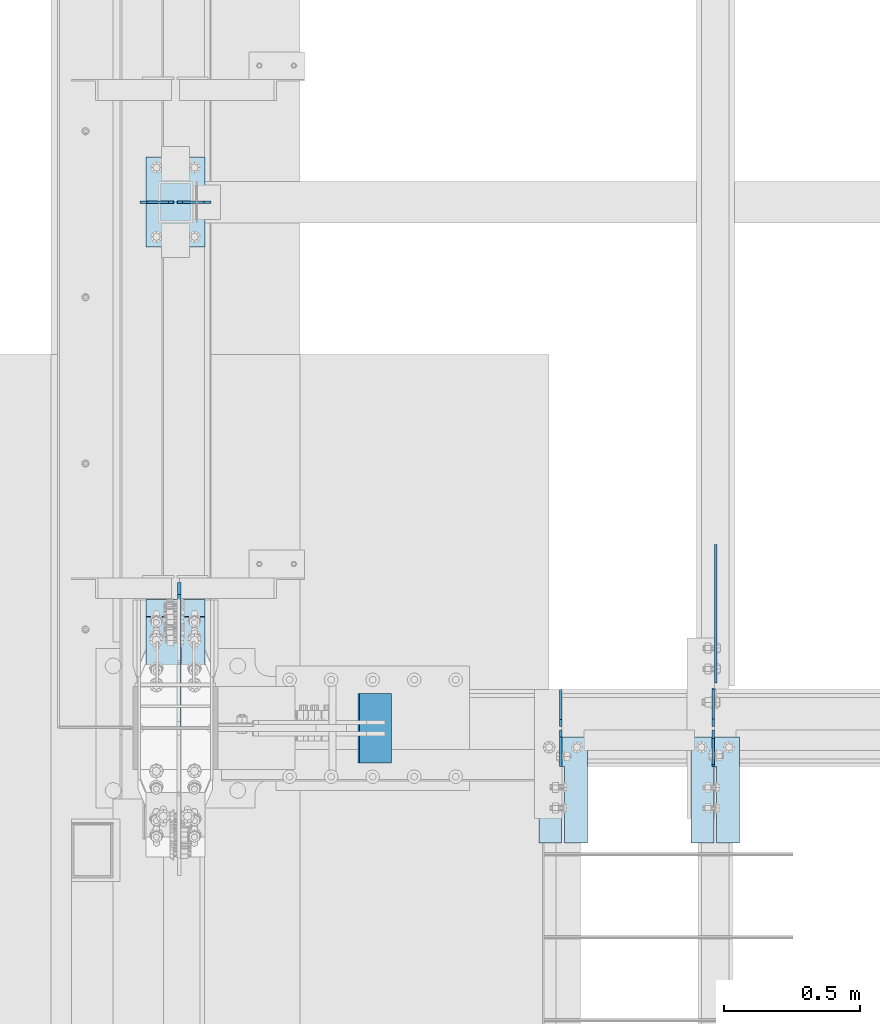
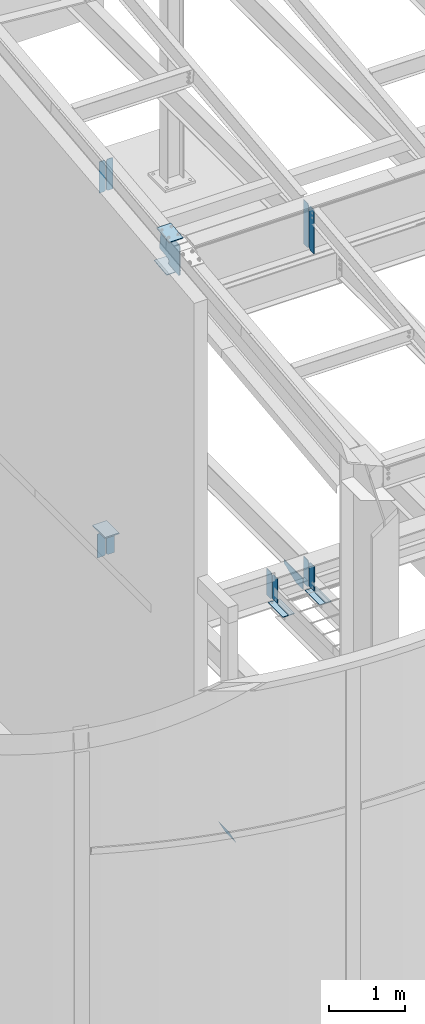
# One storey, part 985 of 1179: 18 plates, 10 elements without a shape of their own.
"""IFC2X3 building model written with IfcOpenShell, lengths in millimetres."""

import ifcopenshell
import ifcopenshell.guid

model = None  # the IFC model being written
_history = None  # IfcOwnerHistory: only IFC2X3 demands one
_inside = {}  # id of a spatial element -> (the spatial element, [elements in it])
_under = {}  # id of a project, library or spatial element -> (it, [spatial elements below it])
_declared = {}  # id of a project -> (the project, [libraries it declares])
_typed = {}  # id of a type object -> (the type object, [elements of that type])
_made_of = {}  # id of a material, layer set ... -> (it, [elements and type objects made of it])


def new_model(schema):
    """Start an empty IFC model of exactly this schema.

    Asked for "IFC4X3", IfcOpenShell would pick the latest addendum, in which some entities
    have other attributes; the version numbers below select the first issue.
    IFC2X3 requires an IfcOwnerHistory on every rooted entity: one is made here for all.
    """
    global model, _history
    if schema == "IFC4X3":
        model = ifcopenshell.file(schema_version=(4, 3, 0, 0))
    else:
        model = ifcopenshell.file(schema=schema)
    _inside.clear()
    _under.clear()
    _declared.clear()
    _typed.clear()
    _made_of.clear()
    _history = None
    if model.schema == "IFC2X3":
        org = make("IfcOrganization", Name="unknown")
        user = make(
            "IfcPersonAndOrganization",
            ThePerson=make("IfcPerson", FamilyName="unknown"),
            TheOrganization=org,
        )
        app = make(
            "IfcApplication",
            ApplicationDeveloper=org,
            Version="unknown",
            ApplicationFullName="unknown",
            ApplicationIdentifier="unknown",
        )
        _history = make(
            "IfcOwnerHistory",
            OwningUser=user,
            OwningApplication=app,
            ChangeAction="ADDED",
            CreationDate=0,
        )
    return model


def make(cls, **values):
    """One entity of the class cls with the attributes given. An attribute that is None is left unset."""
    return model.create_entity(
        cls, **{name: value for name, value in values.items() if value is not None}
    )


def rooted(cls, **values):
    """An entity with a GlobalId (a new one), such as an element, a storey or a relation."""
    return make(cls, GlobalId=ifcopenshell.guid.new(), OwnerHistory=_history, **values)


def si_unit(unit_type, name, prefix=None):
    """IfcSIUnit, for example si_unit("LENGTHUNIT", "METRE", prefix="MILLI")."""
    return make("IfcSIUnit", UnitType=unit_type, Prefix=prefix, Name=name)


def assignment(units):
    """IfcUnitAssignment: the units of a project."""
    return None if units is None else make("IfcUnitAssignment", Units=units)


def point(xyz):
    """IfcCartesianPoint."""
    return None if xyz is None else make("IfcCartesianPoint", Coordinates=xyz)


def direction(xyz):
    """IfcDirection."""
    return None if xyz is None else make("IfcDirection", DirectionRatios=xyz)


def frame(location, z_axis=None, x_axis=None):
    """IfcAxis2Placement3D, a coordinate frame: its origin and axes. An axis left out is left unset."""
    return make(
        "IfcAxis2Placement3D",
        Location=point(location),
        Axis=direction(z_axis),
        RefDirection=direction(x_axis),
    )


def origin_with_axes():
    """The frame at (0, 0, 0) with the z axis (0, 0, 1) and the x axis (1, 0, 0) written out."""
    return frame((0.0, 0.0, 0.0), z_axis=(0.0, 0.0, 1.0), x_axis=(1.0, 0.0, 0.0))


def place(relative_to, where):
    """IfcLocalPlacement: puts the frame where relative to a parent placement (None: the world)."""
    return make(
        "IfcLocalPlacement", PlacementRelTo=relative_to, RelativePlacement=where
    )


def context(
    kind, dimensions, precision=None, world=None, true_north=None, identifier=None
):
    """IfcGeometricRepresentationContext, for example the 3D "Model" context."""
    return make(
        "IfcGeometricRepresentationContext",
        ContextIdentifier=identifier,
        ContextType=kind,
        CoordinateSpaceDimension=dimensions,
        Precision=precision,
        WorldCoordinateSystem=world,
        TrueNorth=true_north,
    )


def subcontext(parent, identifier, kind, view, scale=None):
    """IfcGeometricRepresentationSubContext, for example "Body" below "Model"."""
    return make(
        "IfcGeometricRepresentationSubContext",
        ContextIdentifier=identifier,
        ContextType=kind,
        ParentContext=parent,
        TargetScale=scale,
        TargetView=view,
    )


def project(units=None, contexts=None):
    """IfcProject with its units and contexts."""
    return rooted(
        "IfcProject",
        Name="project",
        RepresentationContexts=contexts,
        UnitsInContext=assignment(units),
    )


def spatial(cls, under=None, at=None, **own):
    """A site, building, storey or space (cls), placed at a placement, below another one or the project."""
    s = rooted(cls, ObjectPlacement=at, **own)
    if under is not None:
        _under.setdefault(under.id(), (under, []))[1].append(s)
    return s


def faces_of(points, faces, orient=None, outer=None):
    """IfcFace entities. A face is a list of loops; a loop is a list of indices into points, from 0.

    orient and outer hold one flag for each loop. By default every Orientation is true, the
    first loop of a face is its IfcFaceOuterBound and the others are IfcFaceBound.
    """
    made = []
    for i, loops in enumerate(faces):
        bounds = []
        for j, loop in enumerate(loops):
            is_outer = j == 0 if outer is None else outer[i][j]
            bounds.append(
                make(
                    "IfcFaceOuterBound" if is_outer else "IfcFaceBound",
                    Bound=make("IfcPolyLoop", Polygon=[points[k] for k in loop]),
                    Orientation=True if orient is None else orient[i][j],
                )
            )
        made.append(make("IfcFace", Bounds=bounds))
    return made


def faceted_brep(points, faces, orient=None, outer=None, voids=None):
    """IfcFacetedBrep: a solid bounded by flat faces; with voids (closed shells), ...WithVoids."""
    shared = [point(p) for p in points]
    hull = make("IfcClosedShell", CfsFaces=faces_of(shared, faces, orient, outer))
    if voids is None:
        return make("IfcFacetedBrep", Outer=hull)
    return make(
        "IfcFacetedBrepWithVoids",
        Outer=hull,
        Voids=[
            make(cls, CfsFaces=faces_of(shared, fs, o, b)) for cls, fs, o, b in voids
        ],
    )


def shape(context_of_items, identifier, shape_type, items):
    """IfcShapeRepresentation: the items that make up one representation, for example the "Body"."""
    return make(
        "IfcShapeRepresentation",
        ContextOfItems=context_of_items,
        RepresentationIdentifier=identifier,
        RepresentationType=shape_type,
        Items=items,
    )


def material(Name=None, Category=None):
    """IfcMaterial."""
    return make("IfcMaterial", Name=Name, Category=Category)


def made_of(thing, what):
    """Note that an element or type object is made of a material, layer set ...; save() writes the relation."""
    if what is not None:
        _made_of.setdefault(what.id(), (what, []))[1].append(thing)
    return thing


def type_object(cls, material=None, **own):
    """A type object (cls), such as IfcWallType, which elements share."""
    return made_of(rooted(cls, **own), material)


def element(
    cls,
    number,
    at=None,
    inside=None,
    cuts=None,
    type_object=None,
    material=None,
    context=None,
    identifier="Body",
    shape_type=None,
    held_by="IfcProductDefinitionShape",
    body=None,
    shapes=None,
    **own,
):
    """One element of the class cls, such as IfcWall. Its Tag is "e" and its number.

    at: its placement. inside: the storey or other place that contains it. cuts: it is an
    opening in that element (IfcRelVoidsElement). A single representation is given by context,
    identifier, shape_type and body (its items); several are given by shapes. held_by: the class
    of the entity that holds the representations. save() writes the other relations.
    """
    e = rooted(cls, Tag="e%d" % number, ObjectPlacement=at, **own)
    if body is not None:
        shapes = [shape(context, identifier, shape_type, body)]
    if shapes is not None:
        e.Representation = make(held_by, Representations=shapes)
    if inside is not None:
        _inside.setdefault(inside.id(), (inside, []))[1].append(e)
    if cuts is not None:
        rooted(
            "IfcRelVoidsElement", RelatingBuildingElement=cuts, RelatedOpeningElement=e
        )
    if type_object is not None:
        _typed.setdefault(type_object.id(), (type_object, []))[1].append(e)
    return made_of(e, material)


def aggregate(whole, parts):
    """IfcRelAggregates: a whole, such as a stair, and the parts it consists of."""
    return rooted("IfcRelAggregates", RelatingObject=whole, RelatedObjects=parts)


def save(model, path):
    """Write the relations noted so far, then the file.

    IfcRelAggregates (storeys below a building ...), IfcRelContainedInSpatialStructure (elements
    in a storey), IfcRelDefinesByType, IfcRelAssociatesMaterial and IfcRelDeclares: one each for
    every whole, place, type object, material and project.
    """
    for whole, parts in _under.values():
        aggregate(whole, parts)
    for where, things in _inside.values():
        rooted(
            "IfcRelContainedInSpatialStructure",
            RelatedElements=things,
            RelatingStructure=where,
        )
    for kind, things in _typed.values():
        rooted("IfcRelDefinesByType", RelatedObjects=things, RelatingType=kind)
    for what, things in _made_of.values():
        rooted("IfcRelAssociatesMaterial", RelatedObjects=things, RelatingMaterial=what)
    for by, libraries in _declared.values():
        rooted("IfcRelDeclares", RelatingContext=by, RelatedDefinitions=libraries)
    model.write(path)


model = new_model("IFC2X3")

# Units and contexts
model_context = context("Model", 3, precision=1e-05, world=origin_with_axes())
body_context = subcontext(model_context, "Body", "Model", "MODEL_VIEW")
ifc_project = project(units=[si_unit("LENGTHUNIT", "METRE", prefix="MILLI"), si_unit("AREAUNIT", "SQUARE_METRE"), si_unit("VOLUMEUNIT", "CUBIC_METRE"), si_unit("MASSUNIT", "GRAM", prefix="KILO"), si_unit("TIMEUNIT", "SECOND"), si_unit("PLANEANGLEUNIT", "RADIAN"), si_unit("SOLIDANGLEUNIT", "STERADIAN"), si_unit("THERMODYNAMICTEMPERATUREUNIT", "DEGREE_CELSIUS"), si_unit("LUMINOUSINTENSITYUNIT", "LUMEN")], contexts=[model_context])

# Site, building, storey
site_placement = place(None, origin_with_axes())
site = spatial("IfcSite", under=ifc_project, at=site_placement, CompositionType="ELEMENT")
building_placement = place(site_placement, origin_with_axes())
building = spatial("IfcBuilding", under=site, at=building_placement, Name="Undefined", CompositionType="ELEMENT")
storey_placement = place(building_placement, origin_with_axes())
storey = spatial("IfcBuildingStorey", under=building, at=storey_placement, Name="Undefined", CompositionType="ELEMENT", Elevation=0.0)

# Assembly, plate
assembly_1_placement = place(storey_placement, origin_with_axes())
assembly_1 = element("IfcElementAssembly", 1, at=assembly_1_placement, inside=storey, Name="BEAM", AssemblyPlace="NOTDEFINED", PredefinedType="RIGID_FRAME")
ifc_material_1 = material(Name="STEEL/A36")
plate_type_1 = type_object("IfcPlateType", PredefinedType="NOTDEFINED")
plate_1_placement = place(assembly_1_placement, frame((2405.85575008397, 5429.2222318038, 9095.0787842795), z_axis=(0.0, 0.0, 1.0), x_axis=(0.0, -1.0, 0.0)))
plate_1 = element("IfcPlate", 2, at=plate_1_placement, type_object=plate_type_1, material=ifc_material_1, Name="PLATE", context=body_context, shape_type="Brep", body=[
    faceted_brep([(1.81898940354586e-12, -4.76249999999709, 31.75), (0.0, -4.76249999999982, 682.625), (0.0, 4.76249999999982, 682.625), (-1.81898940354586e-12, 4.76249999998981, 31.75), (31.75, -4.76249999999982, 714.375), (31.75, 4.76249999999982, 714.375), (127.0, -4.76249999999982, 714.375), (127.0, 4.76249999999982, 714.375), (127.0, -4.76250000000073, 0.0), (127.0, 4.76250000000073, 0.0), (31.7499999988213, -4.76250000001164, 0.0), (31.7499999988249, 4.76249999998254, 0.0)], [[[0, 1, 2, 3]], [[1, 4, 5, 2]], [[4, 6, 7, 5]], [[6, 8, 9, 7]], [[8, 10, 11, 9]], [[10, 0, 3, 11]], [[5, 7, 9, 11, 3, 2]], [[10, 8, 6, 4, 1, 0]]]),
])

# Assembly, plates
assembly_2_placement = place(storey_placement, origin_with_axes())
assembly_2 = element("IfcElementAssembly", 3, at=assembly_2_placement, inside=storey, Name="BEAM", AssemblyPlace="NOTDEFINED", PredefinedType="RIGID_FRAME")
plate_type_2 = type_object("IfcPlateType", PredefinedType="NOTDEFINED")
plate_2_placement = place(assembly_2_placement, frame((1846.2625, 5576.8875, 3656.0125), z_axis=(0.0, 0.0, 1.0), x_axis=(0.0, -1.0, 0.0)))
plate_2 = element("IfcPlate", 4, at=plate_2_placement, type_object=plate_type_2, material=ifc_material_1, Name="PLATE", context=body_context, shape_type="Brep", body=[
    faceted_brep([(0.0, -4.76249999999709, 0.0), (-0.0878909021048457, -4.76250000000005, 425.449987792969), (-0.0878909021048457, 4.76250000000005, 425.449987792969), (0.0, 4.76249999999709, 0.0), (109.449609479365, -4.76250000000005, 425.449987792969), (109.449609479365, 4.76250000000005, 425.449987792969), (134.854856315891, -4.76250000000005, 400.049988716433), (134.854856315891, 4.76250000000005, 400.049988716433), (134.932252782004, -4.76250000000005, 25.399999076536), (134.932252782004, 4.76250000000005, 25.399999076536), (109.53750038147, -4.76250000000005, 0.0), (109.53750038147, 4.76250000000005, 0.0)], [[[0, 1, 2, 3]], [[1, 4, 5, 2]], [[4, 6, 7, 5]], [[6, 8, 9, 7]], [[8, 10, 11, 9]], [[10, 0, 3, 11]], [[5, 7, 9, 11, 3, 2]], [[10, 8, 6, 4, 1, 0]]]),
])
plate_3_placement = place(assembly_2_placement, frame((2405.0625, 5294.3125, 3683.0), z_axis=(0.0, 0.0, 1.0), x_axis=(0.0, 1.0, 0.0)))
plate_3 = element("IfcPlate", 5, at=plate_3_placement, type_object=plate_type_2, material=ifc_material_1, Name="PLATE", context=body_context, shape_type="Brep", body=[
    faceted_brep([(0.0, -4.76249999999709, 0.0), (9.09494701772928e-13, -4.76250000000073, 400.05000038147), (2.72848410531878e-12, 4.76249999999891, 400.05000038147), (0.0, 4.76249999999709, 0.0), (109.53750038147, -4.76249999999982, 400.049987792969), (109.53750038147, 4.76249999999982, 400.049987792969), (134.9375, -4.76249999999982, 374.649988174438), (134.9375, 4.76249999999982, 374.649988174438), (134.937500000001, -4.76250000003438, 0.0), (134.937500000003, 4.76249999996526, 0.0)], [[[0, 1, 2, 3]], [[1, 4, 5, 2]], [[4, 6, 7, 5]], [[6, 8, 9, 7]], [[8, 0, 3, 9]], [[5, 7, 9, 3, 2]], [[8, 6, 4, 1, 0]]]),
])
plate_4_placement = place(assembly_2_placement, frame((1846.2625, 5294.3125, 3683.0), z_axis=(0.0, 0.0, 1.0), x_axis=(0.0, 1.0, 0.0)))
plate_4 = element("IfcPlate", 6, at=plate_4_placement, type_object=plate_type_2, material=ifc_material_1, Name="PLATE", context=body_context, shape_type="Brep", body=[
    faceted_brep([(0.0, -4.76249999999709, 0.0), (9.09494701772928e-13, -4.76250000000073, 400.05000038147), (2.72848410531878e-12, 4.76249999999891, 400.05000038147), (0.0, 4.76249999999709, 0.0), (109.53750038147, -4.76249999999982, 400.049987792969), (109.53750038147, 4.76249999999982, 400.049987792969), (134.9375, -4.76249999999982, 374.649988174438), (134.9375, 4.76249999999982, 374.649988174438), (134.937500000001, -4.76250000003438, 0.0), (134.937500000003, 4.76249999996526, 0.0)], [[[0, 1, 2, 3]], [[1, 4, 5, 2]], [[4, 6, 7, 5]], [[6, 8, 9, 7]], [[8, 0, 3, 9]], [[5, 7, 9, 3, 2]], [[8, 6, 4, 1, 0]]]),
])
plate_5_placement = place(assembly_2_placement, frame((2405.06192754091, 5441.95000011429, 3656.0125), z_axis=(0.0, 0.0, 1.0), x_axis=(0.0, 1.0, 0.0)))
plate_5 = element("IfcPlate", 7, at=plate_5_placement, type_object=plate_type_2, material=ifc_material_1, Name="PLATE", context=body_context, shape_type="Brep", body=[
    faceted_brep([(0.0, -4.76250000000073, 25.3999996185303), (9.09494701772928e-13, -4.76250000000073, 400.05000038147), (2.72848410531878e-12, 4.76249999999891, 400.05000038147), (0.0, 4.76250000000073, 25.3999996185303), (25.3999996185312, -4.76250000000709, 425.45), (25.399999618533, 4.76249999999254, 425.45), (134.937500000001, -4.76250000003438, 425.45), (134.937500000003, 4.76249999996526, 425.45), (134.937500000001, -4.76250000003438, 0.0), (134.937500000003, 4.76249999996526, 0.0), (25.3999996185303, -4.76250000000073, 0.0), (25.3999996185303, 4.76250000000073, 0.0)], [[[0, 1, 2, 3]], [[1, 4, 5, 2]], [[4, 6, 7, 5]], [[6, 8, 9, 7]], [[8, 10, 11, 9]], [[10, 0, 3, 11]], [[5, 7, 9, 11, 3, 2]], [[10, 8, 6, 4, 1, 0]]]),
])
aggregate(assembly_2, [plate_2, plate_3, plate_4, plate_5])

# Plate
plate_type_3 = type_object("IfcPlateType", PredefinedType="NOTDEFINED")
plate_6_placement = place(assembly_1_placement, frame((2405.85575008397, 5441.92241039977, 9095.0787842795), z_axis=(0.0, 0.0, 1.0), x_axis=(0.0, 1.0, 0.0)))
plate_6 = element("IfcPlate", 8, at=plate_6_placement, type_object=plate_type_3, material=ifc_material_1, Name="PLATE", context=body_context, shape_type="Brep", body=[
    faceted_brep([(1.81898940354586e-12, -4.76249999999709, 31.75), (0.0, -4.76249999999982, 682.625), (0.0, 4.76249999999982, 682.625), (-1.81898940354586e-12, 4.76249999998981, 31.75), (31.75, -4.76249999999982, 714.375), (31.75, 4.76249999999982, 714.375), (139.7, -4.76249999999982, 714.375), (139.7, 4.76249999999982, 714.375), (139.7, -4.76249999999982, 0.0), (139.7, 4.76249999999982, 0.0), (31.7499999988213, -4.76250000001164, 0.0), (31.7499999988249, 4.76249999998254, 0.0)], [[[0, 1, 2, 3]], [[1, 4, 5, 2]], [[4, 6, 7, 5]], [[6, 8, 9, 7]], [[8, 10, 11, 9]], [[10, 0, 3, 11]], [[5, 7, 9, 11, 3, 2]], [[10, 8, 6, 4, 1, 0]]]),
])

aggregate(assembly_1, [plate_1, plate_6])

# Assembly, plate
assembly_3_placement = place(storey_placement, origin_with_axes())
assembly_3 = element("IfcElementAssembly", 9, at=assembly_3_placement, inside=storey, Name="COLUMN", AssemblyPlace="NOTDEFINED", PredefinedType="RIGID_FRAME")
plate_type_4 = type_object("IfcPlateType", PredefinedType="NOTDEFINED")
plate_7_placement = place(assembly_3_placement, frame((324.394791494267, 7200.9, 4111.625), z_axis=(0.0, 1.0, 0.0), x_axis=(1.0, 0.0, 0.0)))
plate_7 = element("IfcPlate", 10, at=plate_7_placement, type_object=plate_type_4, material=ifc_material_1, Name="PLATE", context=body_context, shape_type="Brep", body=[
    faceted_brep([(0.0, -9.52499999999964, 0.0), (0.0, -9.52499999999964, 330.200012207031), (0.0, 9.52499999999964, 330.200012207031), (0.0, 9.52499999999964, 0.0), (215.899993896484, -9.52499999999964, 330.200012207031), (215.899993896484, 9.52499999999964, 330.200012207031), (215.900000000001, -9.52499999999964, 0.0), (215.900000000001, 9.52499999999964, 0.0)], [[[0, 1, 2, 3]], [[1, 4, 5, 2]], [[4, 6, 7, 5]], [[6, 0, 3, 7]], [[5, 7, 3, 2]], [[6, 4, 1, 0]]]),
])
aggregate(assembly_3, [plate_7])

assembly_4_placement = place(storey_placement, origin_with_axes())
assembly_4 = element("IfcElementAssembly", 11, at=assembly_4_placement, inside=storey, Name="BEAM", AssemblyPlace="NOTDEFINED", PredefinedType="RIGID_FRAME")
plate_type_5 = type_object("IfcPlateType", PredefinedType="NOTDEFINED")
plate_8_placement = place(assembly_4_placement, frame((2414.5875, 5602.2875, 3698.875), z_axis=(0.0, 1.0, 0.0), x_axis=(0.0, 0.0, -1.0)))
plate_8 = element("IfcPlate", 12, at=plate_8_placement, type_object=plate_type_5, material=ifc_material_1, Name="PLATE", context=body_context, shape_type="Brep", body=[
    faceted_brep([(0.0, -4.76249999999709, 0.0), (0.0, -4.76249999999982, 508.0), (0.0, 4.76249999999982, 508.0), (0.0, 4.76249999999709, 0.0), (50.7999992370605, -4.76249999999982, 508.0), (50.7999992370605, 4.76249999999982, 508.0), (177.800003051758, -4.76249999999982, 190.5), (177.800003051758, 4.76249999999982, 190.5), (177.800003051758, -4.76249999999982, 0.0), (177.800003051758, 4.76249999999982, 0.0)], [[[0, 1, 2, 3]], [[1, 4, 5, 2]], [[4, 6, 7, 5]], [[6, 8, 9, 7]], [[8, 0, 3, 9]], [[5, 7, 9, 3, 2]], [[8, 6, 4, 1, 0]]]),
])
aggregate(assembly_4, [plate_8])

assembly_5_placement = place(storey_placement, origin_with_axes())
assembly_5 = element("IfcElementAssembly", 13, at=assembly_5_placement, inside=storey, Name="BEAM", AssemblyPlace="NOTDEFINED", PredefinedType="RIGID_FRAME")
plate_9_placement = place(assembly_5_placement, frame((2501.9, 5403.85, 3659.1875), z_axis=(0.0, -1.0, 0.0), x_axis=(-1.0, 0.0, 0.0)))
plate_9 = element("IfcPlate", 14, at=plate_9_placement, type_object=plate_type_5, material=ifc_material_1, Name="PLATE", context=body_context, shape_type="Brep", body=[
    faceted_brep([(84.1374995016549, -4.76249999999982, 388.937506103519), (84.1374997809262, -4.76249999999982, 109.537497498053), (84.1374997809262, 4.76249999999982, 109.537497498053), (84.1374995016549, 4.76249999999982, 388.937506103519), (93.6624993994565, -4.76249999999982, 109.537497513039), (93.6624993994565, 4.76249999999982, 109.537497513039), (93.6624981665036, -4.76249999999982, 388.93749748426), (93.6624981665036, 4.76249999999982, 388.937506103519), (0.0, -4.76249999999709, 0.0), (-1.46801176015288e-06, -4.76249999999982, 388.937506103516), (-1.46801176015288e-06, 4.76249999999982, 388.937506103516), (0.0, 4.76249999999709, 0.0), (177.800003051758, -4.76249999999982, 0.0), (177.800003051758, 4.76249999999982, 0.0), (177.799987132177, -4.76249999999982, 388.937506103521), (177.799987132177, 4.76249999999982, 388.937506103521)], [[[0, 1, 2, 3]], [[4, 5, 2, 1]], [[6, 7, 5, 4]], [[8, 9, 10, 11]], [[12, 8, 11, 13]], [[14, 12, 13, 15]], [[1, 0, 9, 8, 12, 14, 6, 4]], [[10, 9, 0, 3]], [[15, 13, 11, 10, 3, 2, 5, 7]], [[14, 15, 7, 6]]]),
])
aggregate(assembly_5, [plate_9])

assembly_6_placement = place(storey_placement, origin_with_axes())
assembly_6 = element("IfcElementAssembly", 15, at=assembly_6_placement, inside=storey, Name="BEAM", AssemblyPlace="NOTDEFINED", PredefinedType="RIGID_FRAME")
plate_10_placement = place(assembly_6_placement, frame((1943.1, 5403.85000000985, 3659.1875), z_axis=(0.0, -1.0, 0.0), x_axis=(-1.0, 0.0, 0.0)))
plate_10 = element("IfcPlate", 16, at=plate_10_placement, type_object=plate_type_5, material=ifc_material_1, Name="PLATE", context=body_context, shape_type="Brep", body=[
    faceted_brep([(84.1374995016549, -4.76249999999982, 388.937506103519), (84.1374997809262, -4.76249999999982, 109.537497498053), (84.1374997809262, 4.76249999999982, 109.537497498053), (84.1374995016549, 4.76249999999982, 388.937506103519), (93.6624993994565, -4.76249999999982, 109.537497513039), (93.6624993994565, 4.76249999999982, 109.537497513039), (93.6624981665036, -4.76249999999982, 388.93749748426), (93.6624981665036, 4.76249999999982, 388.937506103519), (0.0, -4.76249999999709, 0.0), (-1.46801176015288e-06, -4.76249999999982, 388.937506103516), (-1.46801176015288e-06, 4.76249999999982, 388.937506103516), (0.0, 4.76249999999709, 0.0), (177.800003051758, -4.76249999999982, 0.0), (177.800003051758, 4.76249999999982, 0.0), (177.799987132177, -4.76249999999982, 388.937506103521), (177.799987132177, 4.76249999999982, 388.937506103521)], [[[0, 1, 2, 3]], [[4, 5, 2, 1]], [[6, 7, 5, 4]], [[8, 9, 10, 11]], [[12, 8, 11, 13]], [[14, 12, 13, 15]], [[1, 0, 9, 8, 12, 14, 6, 4]], [[10, 9, 0, 3]], [[15, 13, 11, 10, 3, 2, 5, 7]], [[14, 15, 7, 6]]]),
])
aggregate(assembly_6, [plate_10])

# Assembly, plates
assembly_7_placement = place(storey_placement, origin_with_axes())
assembly_7 = element("IfcElementAssembly", 17, at=assembly_7_placement, inside=storey, Name="BEAM", AssemblyPlace="NOTDEFINED", PredefinedType="RIGID_FRAME")
plate_type_6 = type_object("IfcPlateType", PredefinedType="NOTDEFINED")
plate_11_placement = place(assembly_7_placement, frame((327.025000000002, 7366.0, 10053.1386566612), z_axis=(0.0, 0.0, -1.0), x_axis=(1.0, 0.0, 0.0)))
plate_11 = element("IfcPlate", 18, at=plate_11_placement, type_object=plate_type_6, material=ifc_material_1, Name="PLATE", context=body_context, shape_type="Brep", body=[
    faceted_brep([(0.0, -4.76249999999709, 0.0), (0.0, -4.76249999999982, 502.178738035143), (0.0, 4.76249999999982, 502.178738035143), (0.0, 4.76249999999709, 0.0), (78.5812507629395, -4.76249999999982, 502.178738035143), (78.5812507629395, 4.76249999999982, 502.178738035143), (97.63125, -4.76249999999982, 483.128738798083), (97.63125, 4.76249999999982, 483.128738798083), (97.63125, -4.76249999999982, 19.0499992370605), (97.63125, 4.76249999999982, 19.0499992370605), (78.5812507629395, -4.76249999999982, 0.0), (78.5812507629395, 4.76249999999982, 0.0)], [[[0, 1, 2, 3]], [[1, 4, 5, 2]], [[4, 6, 7, 5]], [[6, 8, 9, 7]], [[8, 10, 11, 9]], [[10, 0, 3, 11]], [[5, 7, 9, 11, 3, 2]], [[10, 8, 6, 4, 1, 0]]]),
])
plate_12_placement = place(assembly_7_placement, frame((438.943750000002, 7366.0, 10053.1386566669), z_axis=(0.0, 0.0, -1.0), x_axis=(1.0, 0.0, 0.0)))
plate_12 = element("IfcPlate", 19, at=plate_12_placement, type_object=plate_type_6, material=ifc_material_1, Name="PLATE", context=body_context, shape_type="Brep", body=[
    faceted_brep([(0.0, -4.76250000000073, 19.0499992370605), (0.0, -4.76249999999982, 483.128738803713), (0.0, 4.76249999999982, 483.128738803713), (0.0, 4.76250000000073, 19.0499992370605), (19.0499992370605, -4.76249999999982, 502.178738040773), (19.0499992370605, 4.76249999999982, 502.178738040773), (97.6312499999999, -4.76249999999982, 502.178738040773), (97.6312499999999, 4.76249999999982, 502.178738040773), (97.63125, -4.76249999999982, 0.0), (97.63125, 4.76249999999982, 0.0), (19.0499992370605, -4.76250000000073, 0.0), (19.0499992370605, 4.76250000000073, 0.0)], [[[0, 1, 2, 3]], [[1, 4, 5, 2]], [[4, 6, 7, 5]], [[6, 8, 9, 7]], [[8, 10, 11, 9]], [[10, 0, 3, 11]], [[5, 7, 9, 11, 3, 2]], [[10, 8, 6, 4, 1, 0]]]),
])
aggregate(assembly_7, [plate_11, plate_12])

assembly_8_placement = place(storey_placement, origin_with_axes())
assembly_8 = element("IfcElementAssembly", 20, at=assembly_8_placement, inside=storey, Name="BEAM", AssemblyPlace="NOTDEFINED", PredefinedType="RIGID_FRAME")
plate_type_7 = type_object("IfcPlateType", PredefinedType="NOTDEFINED")
plate_13_placement = place(assembly_8_placement, frame((561.975000000002, 7366.0, 4083.05), z_axis=(0.0, 0.0, -1.0), x_axis=(-1.0, 0.0, 0.0)))
plate_13 = element("IfcPlate", 21, at=plate_13_placement, type_object=plate_type_7, material=ifc_material_1, Name="PLATE", context=body_context, shape_type="Brep", body=[
    faceted_brep([(0.0, -4.76249999999709, 0.0), (0.0, -4.76249999999982, 381.0), (0.0, 4.76249999999982, 381.0), (0.0, 4.76249999999709, 0.0), (102.39374961853, -4.76249999999982, 381.0), (102.39374961853, 4.76249999999982, 381.0), (124.61875, -4.76249999999982, 358.77499961853), (124.61875, 4.76249999999982, 358.77499961853), (124.61875, -4.76249999999982, 22.2250003814697), (124.61875, 4.76249999999982, 22.2250003814697), (102.39374961853, -4.76249999999982, 0.0), (102.39374961853, 4.76249999999982, 0.0)], [[[0, 1, 2, 3]], [[1, 4, 5, 2]], [[4, 6, 7, 5]], [[6, 8, 9, 7]], [[8, 10, 11, 9]], [[10, 0, 3, 11]], [[5, 7, 9, 11, 3, 2]], [[10, 8, 6, 4, 1, 0]]]),
])
plate_14_placement = place(assembly_8_placement, frame((301.625000000002, 7366.0, 4083.05), z_axis=(0.0, 0.0, -1.0), x_axis=(1.0, 0.0, 0.0)))
plate_14 = element("IfcPlate", 22, at=plate_14_placement, type_object=plate_type_7, material=ifc_material_1, Name="PLATE", context=body_context, shape_type="Brep", body=[
    faceted_brep([(0.0, -4.76249999999709, 0.0), (0.0, -4.76249999999982, 381.0), (0.0, 4.76249999999982, 381.0), (0.0, 4.76249999999709, 0.0), (102.39374961853, -4.76249999999982, 381.0), (102.39374961853, 4.76249999999982, 381.0), (124.61875, -4.76249999999982, 358.77499961853), (124.61875, 4.76249999999982, 358.77499961853), (124.61875, -4.76249999999982, 22.2250003814697), (124.61875, 4.76249999999982, 22.2250003814697), (102.39374961853, -4.76249999999982, 0.0), (102.39374961853, 4.76249999999982, 0.0)], [[[0, 1, 2, 3]], [[1, 4, 5, 2]], [[4, 6, 7, 5]], [[6, 8, 9, 7]], [[8, 10, 11, 9]], [[10, 0, 3, 11]], [[5, 7, 9, 11, 3, 2]], [[10, 8, 6, 4, 1, 0]]]),
])
aggregate(assembly_8, [plate_13, plate_14])

assembly_9_placement = place(storey_placement, origin_with_axes())
assembly_9 = element("IfcElementAssembly", 23, at=assembly_9_placement, inside=storey, Name="COLUMN", AssemblyPlace="NOTDEFINED", PredefinedType="RIGID_FRAME")
ifc_material_2 = material(Name="STEEL/A572-GR.50")
plate_type_8 = type_object("IfcPlateType", PredefinedType="NOTDEFINED")
plate_15_placement = place(assembly_9_placement, frame((323.850003061738, 5908.03552396803, 9355.31925256643), z_axis=(1.0, 0.0, 0.0), x_axis=(0.0, -0.993676146336441, -0.112284087038017)))
plate_15 = element("IfcPlate", 24, at=plate_15_placement, type_object=plate_type_8, material=ifc_material_2, Name="PLATE", context=body_context, shape_type="Brep", body=[
    faceted_brep([(0.0, -6.34999999999854, 0.0), (0.0, -6.350000000004, 215.899993896484), (0.0, 6.35000000000582, 215.899993896484), (0.0, 6.34999999999854, 0.0), (330.200000001782, -6.34999999994034, 215.899993896483), (330.200000001782, 6.35000000006767, 215.899993896483), (330.200000001782, -6.34999999994034, -1.47792889038101e-12), (330.200000001782, 6.35000000006767, -1.47792889038101e-12)], [[[0, 1, 2, 3]], [[1, 4, 5, 2]], [[4, 6, 7, 5]], [[6, 0, 3, 7]], [[5, 7, 3, 2]], [[6, 4, 1, 0]]]),
])
plate_16_placement = place(assembly_9_placement, frame((323.850003061738, 5844.9347408607, 9913.73981712537), z_axis=(1.0, 0.0, 0.0), x_axis=(0.0, -0.993676146336441, -0.112284087038017)))
plate_16 = element("IfcPlate", 25, at=plate_16_placement, type_object=plate_type_8, material=ifc_material_2, Name="PLATE", context=body_context, shape_type="Brep", body=[
    faceted_brep([(0.0, -6.34999999999854, 0.0), (0.0, -6.350000000004, 215.899993896484), (0.0, 6.35000000000582, 215.899993896484), (0.0, 6.34999999999854, 0.0), (330.200000001782, -6.34999999994034, 215.899993896483), (330.200000001782, 6.35000000006767, 215.899993896483), (330.200000001782, -6.34999999994034, -1.47792889038101e-12), (330.200000001782, 6.35000000006767, -1.47792889038101e-12)], [[[0, 1, 2, 3]], [[1, 4, 5, 2]], [[4, 6, 7, 5]], [[6, 0, 3, 7]], [[5, 7, 3, 2]], [[6, 4, 1, 0]]]),
])
plate_type_9 = type_object("IfcPlateType", PredefinedType="NOTDEFINED")
plate_17_placement = place(assembly_9_placement, frame((445.293750000002, 5441.16512701549, 9356.66338391753), z_axis=(0.0, 0.663574933899741, 0.748109822886957), x_axis=(0.0, 0.748109822886957, -0.663574933899741)))
plate_17 = element("IfcPlate", 26, at=plate_17_placement, type_object=plate_type_9, material=ifc_material_2, Name="PLATE", context=body_context, shape_type="Brep", body=[
    faceted_brep([(-303.638924812358, -6.35000000000002, 342.321068548375), (-303.034312347357, -6.35000000000002, 370.943747817773), (-303.034312347357, 6.35000000000002, 370.943747817773), (-303.638924812358, 6.35000000000002, 342.321068548375), (0.0, -6.34999999999854, 0.0), (0.0, 6.34999999999854, 0.0), (25.4641550948563, -6.35000000000002, 0.0), (25.4641550948563, 6.35000000000002, 0.0), (204.914479198333, -6.35000000000002, 199.440370047754), (204.914479198333, 6.35000000000002, 199.440370047754), (166.936521492347, -6.35000000000002, 233.611770846084), (166.936521492347, 6.35000000000002, 233.611770846084), (161.003988636194, -6.35000000000002, 241.550587669404), (161.003988636194, 6.35000000000002, 241.550587669404), (158.561096624993, -6.35000000000002, 251.155380080752), (158.561096624993, 6.35000000000002, 251.155380080752), (159.979753622514, -6.35000000000002, 260.963905503408), (159.979753622514, 6.35000000000002, 260.963905503408), (165.04398196108, -6.35000000000002, 269.482904856517), (165.04398196108, 6.35000000000002, 269.482904856517), (317.419180789129, -6.35000000000002, 438.832089346204), (317.419180789129, 6.35000000000002, 438.832089346204), (24.7507064364277, -6.35000000000002, 702.166200560594), (24.7507064364277, 6.35000000000002, 702.166200560594), (-129.564022420001, -6.35000000000002, 530.661430182648), (-129.564022420001, 6.35000000000002, 530.661430182648), (-136.596530353566, -6.35000000000002, 525.40616448276), (-136.596530353566, 6.35000000000002, 525.40616448276), (-145.104823245392, -6.35000000000002, 523.242154898895), (-145.104823245392, 6.35000000000002, 523.242154898895), (-153.793591732676, -6.35000000000002, 524.49885199309), (-153.793591732676, 6.35000000000002, 524.49885199309), (-161.010155806082, -6.35000000000002, 528.788825203077), (-161.060235833891, -6.35000000000002, 528.733166699039), (-161.060235833891, 6.35000000000002, 528.733166699039), (-161.010155806082, 6.35000000000002, 528.788825203077)], [[[0, 1, 2, 3]], [[4, 0, 3, 5]], [[6, 4, 5, 7]], [[8, 6, 7, 9]], [[10, 8, 9, 11]], [[12, 10, 11, 13]], [[14, 12, 13, 15]], [[16, 14, 15, 17]], [[18, 16, 17, 19]], [[20, 18, 19, 21]], [[22, 20, 21, 23]], [[24, 22, 23, 25]], [[26, 24, 25, 27]], [[28, 26, 27, 29]], [[30, 28, 29, 31]], [[1, 0, 4, 6, 8, 10, 12, 14, 16, 18, 20, 22, 24, 26, 28, 30, 32, 33]], [[1, 33, 34, 2]], [[31, 29, 27, 25, 23, 21, 19, 17, 15, 13, 11, 9, 7, 5, 3, 2, 34, 35]], [[30, 31, 35, 32]], [[34, 33, 32, 35]]]),
])
aggregate(assembly_9, [plate_15, plate_16, plate_17])

# Assembly, plate
assembly_10_placement = place(storey_placement, origin_with_axes())
assembly_10 = element("IfcElementAssembly", 27, at=assembly_10_placement, inside=storey, Name="Plate", AssemblyPlace="NOTDEFINED", PredefinedType="RIGID_FRAME")
plate_type_10 = type_object("IfcPlateType", PredefinedType="NOTDEFINED")
plate_18_placement = place(assembly_10_placement, frame((1222.49627917257, 5308.6, 52.4316901703643), z_axis=(-0.461652125829643, 0.0, 0.88706105467266), x_axis=(0.0, 1.0, 0.0)))
plate_18 = element("IfcPlate", 28, at=plate_18_placement, type_object=plate_type_10, material=ifc_material_1, Name="Plate", context=body_context, shape_type="Brep", body=[
    faceted_brep([(0.0, -3.17500000000109, 0.0), (0.0, -3.17499999986103, 253.99999999967), (0.0, 3.17500000013752, 253.999999999668), (0.0, 3.17500000000109, 7.27595761418343e-12), (254.0, -3.17499999986103, 253.99999999967), (254.0, 3.17500000013752, 253.999999999668), (254.0, -3.17500000000109, 9.09494701772928e-13), (254.0, 3.17499999999745, -1.36424205265939e-12)], [[[0, 1, 2, 3]], [[1, 4, 5, 2]], [[4, 6, 7, 5]], [[6, 0, 3, 7]], [[5, 7, 3, 2]], [[6, 4, 1, 0]]]),
])
aggregate(assembly_10, [plate_18])

save(model, "model.ifc")
